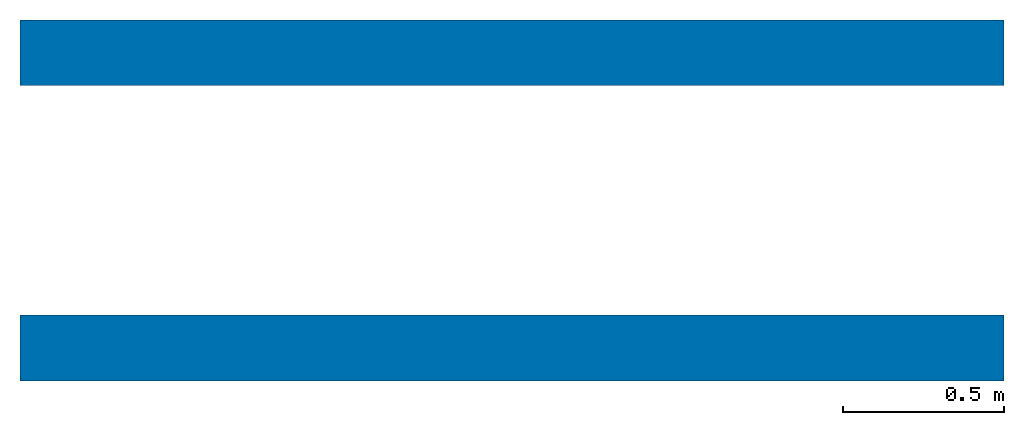
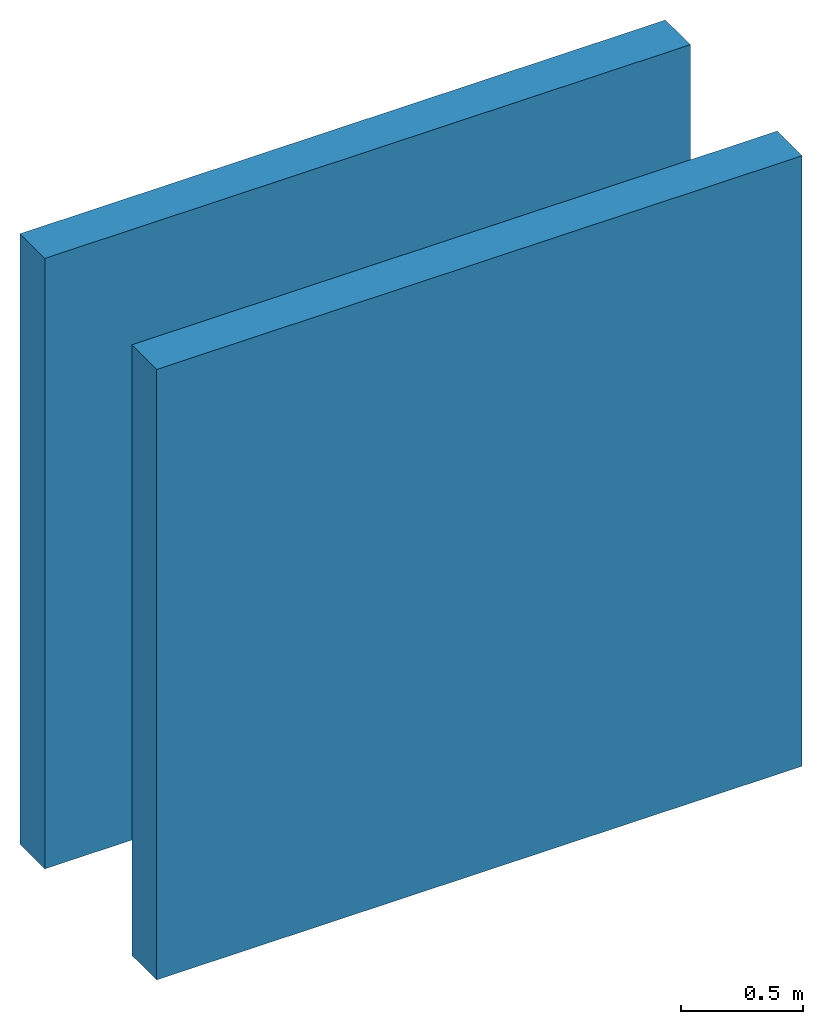
# One storey: 2 walls.
"""IFC2X3 building model written with IfcOpenShell, lengths in feet."""

import ifcopenshell
import ifcopenshell.guid

model = None  # the IFC model being written
_history = None  # IfcOwnerHistory: only IFC2X3 demands one
_inside = {}  # id of a spatial element -> (the spatial element, [elements in it])
_under = {}  # id of a project, library or spatial element -> (it, [spatial elements below it])
_declared = {}  # id of a project -> (the project, [libraries it declares])
_typed = {}  # id of a type object -> (the type object, [elements of that type])
_made_of = {}  # id of a material, layer set ... -> (it, [elements and type objects made of it])


def new_model(schema):
    """Start an empty IFC model of exactly this schema.

    Asked for "IFC4X3", IfcOpenShell would pick the latest addendum, in which some entities
    have other attributes; the version numbers below select the first issue.
    IFC2X3 requires an IfcOwnerHistory on every rooted entity: one is made here for all.
    """
    global model, _history
    if schema == "IFC4X3":
        model = ifcopenshell.file(schema_version=(4, 3, 0, 0))
    else:
        model = ifcopenshell.file(schema=schema)
    _inside.clear()
    _under.clear()
    _declared.clear()
    _typed.clear()
    _made_of.clear()
    _history = None
    if model.schema == "IFC2X3":
        org = make("IfcOrganization", Name="unknown")
        user = make(
            "IfcPersonAndOrganization",
            ThePerson=make("IfcPerson", FamilyName="unknown"),
            TheOrganization=org,
        )
        app = make(
            "IfcApplication",
            ApplicationDeveloper=org,
            Version="unknown",
            ApplicationFullName="unknown",
            ApplicationIdentifier="unknown",
        )
        _history = make(
            "IfcOwnerHistory",
            OwningUser=user,
            OwningApplication=app,
            ChangeAction="ADDED",
            CreationDate=0,
        )
    return model


def make(cls, **values):
    """One entity of the class cls with the attributes given. An attribute that is None is left unset."""
    return model.create_entity(
        cls, **{name: value for name, value in values.items() if value is not None}
    )


def entity(cls, *values):
    """Any entity or typed value of the class cls, its attributes in the order of the schema. None: left unset."""
    e = model.create_entity(cls)
    for i, value in enumerate(values):
        if value is not None:
            e[i] = value
    return e


def rooted(cls, **values):
    """An entity with a GlobalId (a new one), such as an element, a storey or a relation."""
    return make(cls, GlobalId=ifcopenshell.guid.new(), OwnerHistory=_history, **values)


def si_unit(unit_type, name, prefix=None):
    """IfcSIUnit, for example si_unit("LENGTHUNIT", "METRE", prefix="MILLI")."""
    return make("IfcSIUnit", UnitType=unit_type, Prefix=prefix, Name=name)


def converted_unit(unit_type, name, factor, base, dimensions=None, offset=None):
    """IfcConversionBasedUnit, such as the inch: factor (a typed value) times the base unit."""
    return make(
        "IfcConversionBasedUnit"
        if offset is None
        else "IfcConversionBasedUnitWithOffset",
        ConversionOffset=offset,
        Dimensions=None
        if dimensions is None
        else entity("IfcDimensionalExponents", *dimensions),
        UnitType=unit_type,
        Name=name,
        ConversionFactor=make(
            "IfcMeasureWithUnit", ValueComponent=factor, UnitComponent=base
        ),
    )


def derived_unit(unit_type, elements):
    """IfcDerivedUnit: a product of units, each with its exponent."""
    return make(
        "IfcDerivedUnit",
        Elements=[
            make("IfcDerivedUnitElement", Unit=unit, Exponent=power)
            for unit, power in elements
        ],
        UnitType=unit_type,
    )


def assignment(units):
    """IfcUnitAssignment: the units of a project."""
    return None if units is None else make("IfcUnitAssignment", Units=units)


def point(xyz):
    """IfcCartesianPoint."""
    return None if xyz is None else make("IfcCartesianPoint", Coordinates=xyz)


def direction(xyz):
    """IfcDirection."""
    return None if xyz is None else make("IfcDirection", DirectionRatios=xyz)


def frame(location, z_axis=None, x_axis=None):
    """IfcAxis2Placement3D, a coordinate frame: its origin and axes. An axis left out is left unset."""
    return make(
        "IfcAxis2Placement3D",
        Location=point(location),
        Axis=direction(z_axis),
        RefDirection=direction(x_axis),
    )


def frame_2d(location, x_axis=None):
    """IfcAxis2Placement2D, a coordinate frame in the plane: its origin and x axis."""
    return make(
        "IfcAxis2Placement2D", Location=point(location), RefDirection=direction(x_axis)
    )


def origin():
    """The frame at (0, 0, 0) with its axes left unset."""
    return frame((0.0, 0.0, 0.0))


def place(relative_to, where):
    """IfcLocalPlacement: puts the frame where relative to a parent placement (None: the world)."""
    return make(
        "IfcLocalPlacement", PlacementRelTo=relative_to, RelativePlacement=where
    )


def context(
    kind, dimensions, precision=None, world=None, true_north=None, identifier=None
):
    """IfcGeometricRepresentationContext, for example the 3D "Model" context."""
    return make(
        "IfcGeometricRepresentationContext",
        ContextIdentifier=identifier,
        ContextType=kind,
        CoordinateSpaceDimension=dimensions,
        Precision=precision,
        WorldCoordinateSystem=world,
        TrueNorth=true_north,
    )


def subcontext(parent, identifier, kind, view, scale=None):
    """IfcGeometricRepresentationSubContext, for example "Body" below "Model"."""
    return make(
        "IfcGeometricRepresentationSubContext",
        ContextIdentifier=identifier,
        ContextType=kind,
        ParentContext=parent,
        TargetScale=scale,
        TargetView=view,
    )


def project(units=None, contexts=None):
    """IfcProject with its units and contexts."""
    return rooted(
        "IfcProject",
        Name="project",
        RepresentationContexts=contexts,
        UnitsInContext=assignment(units),
    )


def spatial(cls, under=None, at=None, **own):
    """A site, building, storey or space (cls), placed at a placement, below another one or the project."""
    s = rooted(cls, ObjectPlacement=at, **own)
    if under is not None:
        _under.setdefault(under.id(), (under, []))[1].append(s)
    return s


def profile(cls, at=None, kind="AREA", **sizes):
    """A parametric profile (cls). Its sizes go by their IFC names, for example OverallWidth=200.0."""
    return make(cls, ProfileType=kind, Position=at, **sizes)


def rectangle(**sizes):
    """IfcRectangleProfileDef."""
    return profile("IfcRectangleProfileDef", **sizes)


def extrude(swept, where, along, depth):
    """IfcExtrudedAreaSolid: the profile swept, set in the frame where, extruded along a direction by depth."""
    return make(
        "IfcExtrudedAreaSolid",
        SweptArea=swept,
        Position=where,
        ExtrudedDirection=direction(along),
        Depth=depth,
    )


def shape(context_of_items, identifier, shape_type, items):
    """IfcShapeRepresentation: the items that make up one representation, for example the "Body"."""
    return make(
        "IfcShapeRepresentation",
        ContextOfItems=context_of_items,
        RepresentationIdentifier=identifier,
        RepresentationType=shape_type,
        Items=items,
    )


def material(Name=None, Category=None):
    """IfcMaterial."""
    return make("IfcMaterial", Name=Name, Category=Category)


def layer(
    of_material, thickness, ventilated=None, Name=None, Category=None, Priority=None
):
    """IfcMaterialLayer: one layer of a wall or slab, of a material (None: an air gap)."""
    return make(
        "IfcMaterialLayer",
        Material=of_material,
        LayerThickness=thickness,
        IsVentilated=ventilated,
        Name=Name,
        Category=Category,
        Priority=Priority,
    )


def layer_set(layers, Name=None):
    """IfcMaterialLayerSet."""
    return make("IfcMaterialLayerSet", MaterialLayers=layers, LayerSetName=Name)


def layer_usage(for_layer_set, set_direction, sense, offset, extent=None):
    """IfcMaterialLayerSetUsage: how a layer set lies in its element."""
    return make(
        "IfcMaterialLayerSetUsage",
        ForLayerSet=for_layer_set,
        LayerSetDirection=set_direction,
        DirectionSense=sense,
        OffsetFromReferenceLine=offset,
        ReferenceExtent=extent,
    )


def made_of(thing, what):
    """Note that an element or type object is made of a material, layer set ...; save() writes the relation."""
    if what is not None:
        _made_of.setdefault(what.id(), (what, []))[1].append(thing)
    return thing


def type_object(cls, material=None, **own):
    """A type object (cls), such as IfcWallType, which elements share."""
    return made_of(rooted(cls, **own), material)


def element(
    cls,
    number,
    at=None,
    inside=None,
    cuts=None,
    type_object=None,
    material=None,
    context=None,
    identifier="Body",
    shape_type=None,
    held_by="IfcProductDefinitionShape",
    body=None,
    shapes=None,
    **own,
):
    """One element of the class cls, such as IfcWall. Its Tag is "e" and its number.

    at: its placement. inside: the storey or other place that contains it. cuts: it is an
    opening in that element (IfcRelVoidsElement). A single representation is given by context,
    identifier, shape_type and body (its items); several are given by shapes. held_by: the class
    of the entity that holds the representations. save() writes the other relations.
    """
    e = rooted(cls, Tag="e%d" % number, ObjectPlacement=at, **own)
    if body is not None:
        shapes = [shape(context, identifier, shape_type, body)]
    if shapes is not None:
        e.Representation = make(held_by, Representations=shapes)
    if inside is not None:
        _inside.setdefault(inside.id(), (inside, []))[1].append(e)
    if cuts is not None:
        rooted(
            "IfcRelVoidsElement", RelatingBuildingElement=cuts, RelatedOpeningElement=e
        )
    if type_object is not None:
        _typed.setdefault(type_object.id(), (type_object, []))[1].append(e)
    return made_of(e, material)


def aggregate(whole, parts):
    """IfcRelAggregates: a whole, such as a stair, and the parts it consists of."""
    return rooted("IfcRelAggregates", RelatingObject=whole, RelatedObjects=parts)


def save(model, path):
    """Write the relations noted so far, then the file.

    IfcRelAggregates (storeys below a building ...), IfcRelContainedInSpatialStructure (elements
    in a storey), IfcRelDefinesByType, IfcRelAssociatesMaterial and IfcRelDeclares: one each for
    every whole, place, type object, material and project.
    """
    for whole, parts in _under.values():
        aggregate(whole, parts)
    for where, things in _inside.values():
        rooted(
            "IfcRelContainedInSpatialStructure",
            RelatedElements=things,
            RelatingStructure=where,
        )
    for kind, things in _typed.values():
        rooted("IfcRelDefinesByType", RelatedObjects=things, RelatingType=kind)
    for what, things in _made_of.values():
        rooted("IfcRelAssociatesMaterial", RelatedObjects=things, RelatingMaterial=what)
    for by, libraries in _declared.values():
        rooted("IfcRelDeclares", RelatingContext=by, RelatedDefinitions=libraries)
    model.write(path)


model = new_model("IFC2X3")

# Units and contexts
model_context = context("Model", 3, precision=0.0001, world=origin(), true_north=direction((6.12303176911189e-17, 1.0)))
body_context = subcontext(model_context, "Body", "Model", "MODEL_VIEW")
ifc_project = project(units=[converted_unit("LENGTHUNIT", "FOOT", entity("IfcRatioMeasure", 0.3048), si_unit("LENGTHUNIT", "METRE"), dimensions=[1, 0, 0, 0, 0, 0, 0]), converted_unit("AREAUNIT", "SQUARE FOOT", entity("IfcRatioMeasure", 0.09290304), si_unit("AREAUNIT", "SQUARE_METRE"), dimensions=[2, 0, 0, 0, 0, 0, 0]), converted_unit("VOLUMEUNIT", "CUBIC FOOT", entity("IfcRatioMeasure", 0.028316846592), si_unit("VOLUMEUNIT", "CUBIC_METRE"), dimensions=[3, 0, 0, 0, 0, 0, 0]), converted_unit("PLANEANGLEUNIT", "DEGREE", entity("IfcRatioMeasure", 0.0174532925199433), si_unit("PLANEANGLEUNIT", "RADIAN"), dimensions=[0, 0, 0, 0, 0, 0, 0]), si_unit("MASSUNIT", "GRAM", prefix="KILO"), si_unit("TIMEUNIT", "SECOND"), si_unit("FREQUENCYUNIT", "HERTZ"), si_unit("THERMODYNAMICTEMPERATUREUNIT", "DEGREE_CELSIUS"), derived_unit("THERMALTRANSMITTANCEUNIT", [(si_unit("MASSUNIT", "GRAM", prefix="KILO"), 1), (si_unit("THERMODYNAMICTEMPERATUREUNIT", "KELVIN"), -1), (si_unit("TIMEUNIT", "SECOND"), -3)]), derived_unit("VOLUMETRICFLOWRATEUNIT", [(si_unit("LENGTHUNIT", "METRE"), 3), (si_unit("TIMEUNIT", "SECOND"), -1)]), si_unit("ELECTRICCURRENTUNIT", "AMPERE"), si_unit("ELECTRICVOLTAGEUNIT", "VOLT"), si_unit("POWERUNIT", "WATT"), si_unit("FORCEUNIT", "NEWTON"), si_unit("ILLUMINANCEUNIT", "LUX"), si_unit("LUMINOUSFLUXUNIT", "LUMEN"), si_unit("LUMINOUSINTENSITYUNIT", "CANDELA"), derived_unit("USERDEFINED", [(si_unit("MASSUNIT", "GRAM", prefix="KILO"), -1), (si_unit("LENGTHUNIT", "METRE"), -2), (si_unit("TIMEUNIT", "SECOND"), 3), (si_unit("LUMINOUSFLUXUNIT", "LUMEN"), 1)]), derived_unit("LINEARVELOCITYUNIT", [(si_unit("LENGTHUNIT", "METRE"), 1), (si_unit("TIMEUNIT", "SECOND"), -1)]), si_unit("PRESSUREUNIT", "PASCAL"), derived_unit("USERDEFINED", [(si_unit("LENGTHUNIT", "METRE"), -2), (si_unit("MASSUNIT", "GRAM", prefix="KILO"), 1), (si_unit("TIMEUNIT", "SECOND"), -2)])], contexts=[model_context])

# Site, building, storey
site_placement = place(None, origin())
site = spatial("IfcSite", under=ifc_project, at=site_placement, CompositionType="ELEMENT")
building_placement = place(site_placement, origin())
building = spatial("IfcBuilding", under=site, at=building_placement, CompositionType="ELEMENT")
storey_placement = place(building_placement, origin())
storey = spatial("IfcBuildingStorey", under=building, at=storey_placement, Name="Level 1", CompositionType="ELEMENT", Elevation=0.0)

# Walls
ifc_material = material(Name="Default Wall")
ifc_layer = layer(ifc_material, 0.666666666666667)
ifc_layer_set = layer_set([ifc_layer])
ifc_layer_usage_1 = layer_usage(ifc_layer_set, "AXIS2", "NEGATIVE", 0.333333333333333)
wall_type = type_object("IfcWallType", PredefinedType="STANDARD", material=ifc_layer_set)
wall_1_placement = place(storey_placement, origin())
element("IfcWallStandardCase", 1, at=wall_1_placement, inside=storey, type_object=wall_type, material=ifc_layer_usage_1, context=body_context, shape_type="SweptSolid", body=[
    extrude(rectangle(XDim=10.0, YDim=0.666666666666667, at=frame_2d((5.0, 0.0), x_axis=(-1.0, 0.0))), origin(), (0.0, 0.0, 1.0), 10.0),
])
ifc_layer_usage_2 = layer_usage(ifc_layer_set, "AXIS2", "NEGATIVE", 0.333333333333333)
wall_2_placement = place(storey_placement, frame((0.0, 3.0, 0.0)))
element("IfcWallStandardCase", 2, at=wall_2_placement, inside=storey, type_object=wall_type, material=ifc_layer_usage_2, context=body_context, shape_type="SweptSolid", body=[
    extrude(rectangle(XDim=10.0, YDim=0.666666666666667, at=frame_2d((5.0, 5.55111512312578e-17), x_axis=(-1.0, 0.0))), origin(), (0.0, 0.0, 1.0), 10.0),
])

save(model, "model.ifc")
